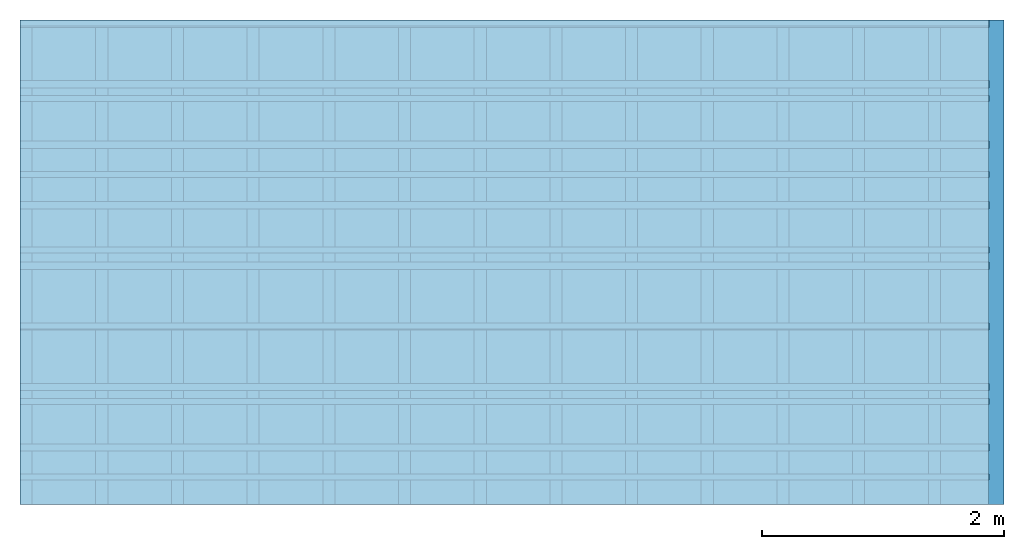
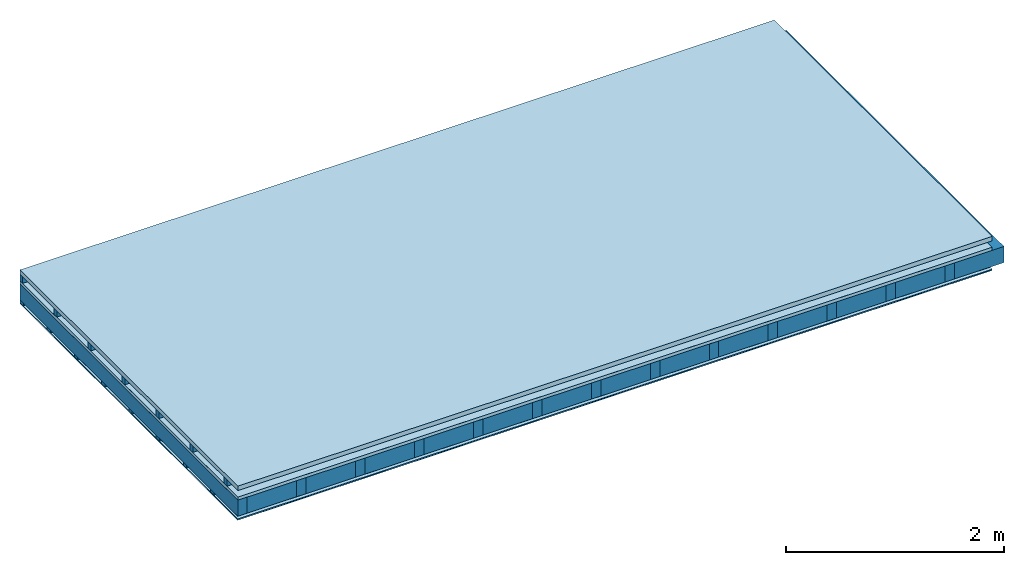
# One storey: 6 plates, 4 members, 1 element without a shape of its own.
"""IFC4 building model written with IfcOpenShell, lengths in metres."""

from ifc_helpers import new_model, si_unit, derived_unit, direction, frame, frame_2d, origin, origin_with_axes, place, context, project, spatial, rectangle, extrude, material, layer, layer_set, type_object, element, aggregate, save


model = new_model("IFC4")

# Units and contexts
plan_context = context("Plan", 3, precision=1e-05, world=origin(), true_north=direction((0.0, 1.0)))
model_context = context("Model", 3, precision=1e-05, world=origin(), true_north=direction((0.0, 1.0)))
ifc_project = project(units=[si_unit("LENGTHUNIT", "METRE"), derived_unit("SOUNDPRESSUREUNIT", [(si_unit("PRESSUREUNIT", "PASCAL", prefix="MICRO"), 0)]), si_unit("ENERGYUNIT", "JOULE", prefix="MEGA"), si_unit("MASSUNIT", "GRAM", prefix="KILO"), derived_unit("THERMALTRANSMITTANCEUNIT", [(si_unit("POWERUNIT", "WATT"), 1), (si_unit("AREAUNIT", "SQUARE_METRE"), -1), (si_unit("THERMODYNAMICTEMPERATUREUNIT", "KELVIN"), -1)]), derived_unit("AREADENSITYUNIT", [(si_unit("MASSUNIT", "GRAM", prefix="KILO"), 1), (si_unit("AREAUNIT", "SQUARE_METRE"), -1)]), derived_unit("USERDEFINED", [(si_unit("ENERGYUNIT", "JOULE", prefix="MEGA"), 1), (si_unit("AREAUNIT", "SQUARE_METRE"), -1)])], contexts=[plan_context, model_context])

# Site, building, storey
site = spatial("IfcSite", under=ifc_project)
building_placement = place(None, origin())
building = spatial("IfcBuilding", under=site, at=building_placement)
storey_placement = place(building_placement, origin())
storey = spatial("IfcBuildingStorey", under=building, at=storey_placement)

# Slab, members, plates
ifc_material_1 = material(Name="Roof tiles", Category="03.015")
ifc_layer_1 = layer(ifc_material_1, 0.05, Name="Roofing")
ifc_layer_2 = layer(None, 0.072, Name="Battens / profiles")
ifc_material_2 = material(Name="Roofing underlay", Category="09.008")
ifc_layer_3 = layer(ifc_material_2, 0.00018, Name="Under the roof")
ifc_material_3 = material(Category="10.009")
ifc_layer_4 = layer(ifc_material_3, 0.035, Name="Sub-floor")
ifc_material_4 = material(Name="of the art")
ifc_layer_5 = layer(ifc_material_4, 0.0, Name="Bond")
ifc_layer_6 = layer(None, 0.18, Name="Supporting structure")
ifc_material_5 = material(Name="Vapor barrier polyethylene (PE)", Category="09.002")
ifc_layer_7 = layer(ifc_material_5, 0.00025, Name="Vapor barrier")
ifc_layer_8 = layer(None, 0.03, Name="Battens / profiles")
ifc_material_6 = material(Name="Plasterboard type A", Category="03.008")
ifc_layer_9 = layer(ifc_material_6, 0.0125, Name="Covering below 1st layer")
ifc_material_7 = material(Category="04.001")
ifc_layer_10 = layer(ifc_material_7, 0.003, Name="Surface below")
ifc_layer_set = layer_set([ifc_layer_1, ifc_layer_2, ifc_layer_3, ifc_layer_4, ifc_layer_5, ifc_layer_6, ifc_layer_7, ifc_layer_8, ifc_layer_9, ifc_layer_10])
slab_type = type_object("IfcSlabType", Name="E0187", PredefinedType="NOTDEFINED", material=ifc_layer_set)
slab_placement = place(None, frame((0.0, 0.0, 0.0), z_axis=(0.0, 0.0, -1.0), x_axis=(1.0, 0.0, 0.0)))
slab = element("IfcSlab", 1, at=slab_placement, inside=storey, type_object=slab_type, material=ifc_layer_set, Name="Slab #1")
ifc_material_8 = material()
member_1_placement = place(slab_placement, origin())
member_1 = element("IfcMember", 2, at=member_1_placement, material=ifc_material_8, Name="Battens / profiles", context=plan_context, shape_type="SweptSolid", body=[
    extrude(rectangle(XDim=0.05, YDim=0.072, at=frame_2d((0.025, 0.036), x_axis=(1.0, 0.0))), frame((0.0, 0.0, 0.05), z_axis=(1.0, 0.0, 0.0), x_axis=(0.0, 1.0, 0.0)), (0.0, 0.0, 1.0), 8.0),
    extrude(rectangle(XDim=0.05, YDim=0.072, at=frame_2d((0.025, 0.036), x_axis=(1.0, 0.0))), frame((0.0, 0.625, 0.05), z_axis=(1.0, 0.0, 0.0), x_axis=(0.0, 1.0, 0.0)), (0.0, 0.0, 1.0), 8.0),
    extrude(rectangle(XDim=0.05, YDim=0.072, at=frame_2d((0.025, 0.036), x_axis=(1.0, 0.0))), frame((0.0, 1.25, 0.05), z_axis=(1.0, 0.0, 0.0), x_axis=(0.0, 1.0, 0.0)), (0.0, 0.0, 1.0), 8.0),
    extrude(rectangle(XDim=0.05, YDim=0.072, at=frame_2d((0.025, 0.036), x_axis=(1.0, 0.0))), frame((0.0, 1.875, 0.05), z_axis=(1.0, 0.0, 0.0), x_axis=(0.0, 1.0, 0.0)), (0.0, 0.0, 1.0), 8.0),
    extrude(rectangle(XDim=0.05, YDim=0.072, at=frame_2d((0.025, 0.036), x_axis=(1.0, 0.0))), frame((0.0, 2.5, 0.05), z_axis=(1.0, 0.0, 0.0), x_axis=(0.0, 1.0, 0.0)), (0.0, 0.0, 1.0), 8.0),
    extrude(rectangle(XDim=0.05, YDim=0.072, at=frame_2d((0.025, 0.036), x_axis=(1.0, 0.0))), frame((0.0, 3.125, 0.05), z_axis=(1.0, 0.0, 0.0), x_axis=(0.0, 1.0, 0.0)), (0.0, 0.0, 1.0), 8.0),
    extrude(rectangle(XDim=0.05, YDim=0.072, at=frame_2d((0.025, 0.036), x_axis=(1.0, 0.0))), frame((0.0, 3.75, 0.05), z_axis=(1.0, 0.0, 0.0), x_axis=(0.0, 1.0, 0.0)), (0.0, 0.0, 1.0), 8.0),
])
ifc_material_9 = material()
member_2_placement = place(slab_placement, origin())
member_2 = element("IfcMember", 3, at=member_2_placement, material=ifc_material_9, Name="Supporting structure", context=plan_context, shape_type="SweptSolid", body=[
    extrude(rectangle(XDim=0.1, YDim=0.18, at=frame_2d((0.05, 0.09), x_axis=(1.0, 0.0))), frame((0.0, 4.0, 0.15718), z_axis=(0.0, -1.0, 0.0), x_axis=(1.0, 0.0, 0.0)), (0.0, 0.0, 1.0), 4.0),
    extrude(rectangle(XDim=0.1, YDim=0.18, at=frame_2d((0.05, 0.09), x_axis=(1.0, 0.0))), frame((0.625, 4.0, 0.15718), z_axis=(0.0, -1.0, 0.0), x_axis=(1.0, 0.0, 0.0)), (0.0, 0.0, 1.0), 4.0),
    extrude(rectangle(XDim=0.1, YDim=0.18, at=frame_2d((0.05, 0.09), x_axis=(1.0, 0.0))), frame((1.25, 4.0, 0.15718), z_axis=(0.0, -1.0, 0.0), x_axis=(1.0, 0.0, 0.0)), (0.0, 0.0, 1.0), 4.0),
    extrude(rectangle(XDim=0.1, YDim=0.18, at=frame_2d((0.05, 0.09), x_axis=(1.0, 0.0))), frame((1.875, 4.0, 0.15718), z_axis=(0.0, -1.0, 0.0), x_axis=(1.0, 0.0, 0.0)), (0.0, 0.0, 1.0), 4.0),
    extrude(rectangle(XDim=0.1, YDim=0.18, at=frame_2d((0.05, 0.09), x_axis=(1.0, 0.0))), frame((2.5, 4.0, 0.15718), z_axis=(0.0, -1.0, 0.0), x_axis=(1.0, 0.0, 0.0)), (0.0, 0.0, 1.0), 4.0),
    extrude(rectangle(XDim=0.1, YDim=0.18, at=frame_2d((0.05, 0.09), x_axis=(1.0, 0.0))), frame((3.125, 4.0, 0.15718), z_axis=(0.0, -1.0, 0.0), x_axis=(1.0, 0.0, 0.0)), (0.0, 0.0, 1.0), 4.0),
    extrude(rectangle(XDim=0.1, YDim=0.18, at=frame_2d((0.05, 0.09), x_axis=(1.0, 0.0))), frame((3.75, 4.0, 0.15718), z_axis=(0.0, -1.0, 0.0), x_axis=(1.0, 0.0, 0.0)), (0.0, 0.0, 1.0), 4.0),
    extrude(rectangle(XDim=0.1, YDim=0.18, at=frame_2d((0.05, 0.09), x_axis=(1.0, 0.0))), frame((4.375, 4.0, 0.15718), z_axis=(0.0, -1.0, 0.0), x_axis=(1.0, 0.0, 0.0)), (0.0, 0.0, 1.0), 4.0),
    extrude(rectangle(XDim=0.1, YDim=0.18, at=frame_2d((0.05, 0.09), x_axis=(1.0, 0.0))), frame((5.0, 4.0, 0.15718), z_axis=(0.0, -1.0, 0.0), x_axis=(1.0, 0.0, 0.0)), (0.0, 0.0, 1.0), 4.0),
    extrude(rectangle(XDim=0.1, YDim=0.18, at=frame_2d((0.05, 0.09), x_axis=(1.0, 0.0))), frame((5.625, 4.0, 0.15718), z_axis=(0.0, -1.0, 0.0), x_axis=(1.0, 0.0, 0.0)), (0.0, 0.0, 1.0), 4.0),
    extrude(rectangle(XDim=0.1, YDim=0.18, at=frame_2d((0.05, 0.09), x_axis=(1.0, 0.0))), frame((6.25, 4.0, 0.15718), z_axis=(0.0, -1.0, 0.0), x_axis=(1.0, 0.0, 0.0)), (0.0, 0.0, 1.0), 4.0),
    extrude(rectangle(XDim=0.1, YDim=0.18, at=frame_2d((0.05, 0.09), x_axis=(1.0, 0.0))), frame((6.875, 4.0, 0.15718), z_axis=(0.0, -1.0, 0.0), x_axis=(1.0, 0.0, 0.0)), (0.0, 0.0, 1.0), 4.0),
    extrude(rectangle(XDim=0.1, YDim=0.18, at=frame_2d((0.05, 0.09), x_axis=(1.0, 0.0))), frame((7.5, 4.0, 0.15718), z_axis=(0.0, -1.0, 0.0), x_axis=(1.0, 0.0, 0.0)), (0.0, 0.0, 1.0), 4.0),
])
ifc_material_10 = material(Name="Mineral wool")
member_3_placement = place(slab_placement, origin())
member_3 = element("IfcMember", 4, at=member_3_placement, material=ifc_material_10, Name="Cavity", context=plan_context, shape_type="SweptSolid", body=[
    extrude(rectangle(XDim=0.525, YDim=0.18, at=frame_2d((0.2625, 0.09), x_axis=(1.0, 0.0))), frame((0.1, 4.0, 0.15718), z_axis=(0.0, -1.0, 0.0), x_axis=(1.0, 0.0, 0.0)), (0.0, 0.0, 1.0), 4.0),
    extrude(rectangle(XDim=0.525, YDim=0.18, at=frame_2d((0.2625, 0.09), x_axis=(1.0, 0.0))), frame((0.725, 4.0, 0.15718), z_axis=(0.0, -1.0, 0.0), x_axis=(1.0, 0.0, 0.0)), (0.0, 0.0, 1.0), 4.0),
    extrude(rectangle(XDim=0.525, YDim=0.18, at=frame_2d((0.2625, 0.09), x_axis=(1.0, 0.0))), frame((1.35, 4.0, 0.15718), z_axis=(0.0, -1.0, 0.0), x_axis=(1.0, 0.0, 0.0)), (0.0, 0.0, 1.0), 4.0),
    extrude(rectangle(XDim=0.525, YDim=0.18, at=frame_2d((0.2625, 0.09), x_axis=(1.0, 0.0))), frame((1.975, 4.0, 0.15718), z_axis=(0.0, -1.0, 0.0), x_axis=(1.0, 0.0, 0.0)), (0.0, 0.0, 1.0), 4.0),
    extrude(rectangle(XDim=0.525, YDim=0.18, at=frame_2d((0.2625, 0.09), x_axis=(1.0, 0.0))), frame((2.6, 4.0, 0.15718), z_axis=(0.0, -1.0, 0.0), x_axis=(1.0, 0.0, 0.0)), (0.0, 0.0, 1.0), 4.0),
    extrude(rectangle(XDim=0.525, YDim=0.18, at=frame_2d((0.2625, 0.09), x_axis=(1.0, 0.0))), frame((3.225, 4.0, 0.15718), z_axis=(0.0, -1.0, 0.0), x_axis=(1.0, 0.0, 0.0)), (0.0, 0.0, 1.0), 4.0),
    extrude(rectangle(XDim=0.525, YDim=0.18, at=frame_2d((0.2625, 0.09), x_axis=(1.0, 0.0))), frame((3.85, 4.0, 0.15718), z_axis=(0.0, -1.0, 0.0), x_axis=(1.0, 0.0, 0.0)), (0.0, 0.0, 1.0), 4.0),
    extrude(rectangle(XDim=0.525, YDim=0.18, at=frame_2d((0.2625, 0.09), x_axis=(1.0, 0.0))), frame((4.475, 4.0, 0.15718), z_axis=(0.0, -1.0, 0.0), x_axis=(1.0, 0.0, 0.0)), (0.0, 0.0, 1.0), 4.0),
    extrude(rectangle(XDim=0.525, YDim=0.18, at=frame_2d((0.2625, 0.09), x_axis=(1.0, 0.0))), frame((5.1, 4.0, 0.15718), z_axis=(0.0, -1.0, 0.0), x_axis=(1.0, 0.0, 0.0)), (0.0, 0.0, 1.0), 4.0),
    extrude(rectangle(XDim=0.525, YDim=0.18, at=frame_2d((0.2625, 0.09), x_axis=(1.0, 0.0))), frame((5.725, 4.0, 0.15718), z_axis=(0.0, -1.0, 0.0), x_axis=(1.0, 0.0, 0.0)), (0.0, 0.0, 1.0), 4.0),
    extrude(rectangle(XDim=0.525, YDim=0.18, at=frame_2d((0.2625, 0.09), x_axis=(1.0, 0.0))), frame((6.35, 4.0, 0.15718), z_axis=(0.0, -1.0, 0.0), x_axis=(1.0, 0.0, 0.0)), (0.0, 0.0, 1.0), 4.0),
    extrude(rectangle(XDim=0.525, YDim=0.18, at=frame_2d((0.2625, 0.09), x_axis=(1.0, 0.0))), frame((6.975, 4.0, 0.15718), z_axis=(0.0, -1.0, 0.0), x_axis=(1.0, 0.0, 0.0)), (0.0, 0.0, 1.0), 4.0),
    extrude(rectangle(XDim=0.525, YDim=0.18, at=frame_2d((0.2625, 0.09), x_axis=(1.0, 0.0))), frame((7.6, 4.0, 0.15718), z_axis=(0.0, -1.0, 0.0), x_axis=(1.0, 0.0, 0.0)), (0.0, 0.0, 1.0), 4.0),
])
ifc_material_11 = material()
member_4_placement = place(slab_placement, origin())
member_4 = element("IfcMember", 5, at=member_4_placement, material=ifc_material_11, Name="Battens / profiles", context=plan_context, shape_type="SweptSolid", body=[
    extrude(rectangle(XDim=0.06, YDim=0.03, at=frame_2d((0.03, 0.015), x_axis=(1.0, 0.0))), frame((0.0, 0.0, 0.33743), z_axis=(1.0, 0.0, 0.0), x_axis=(0.0, 1.0, 0.0)), (0.0, 0.0, 1.0), 8.0),
    extrude(rectangle(XDim=0.06, YDim=0.03, at=frame_2d((0.03, 0.015), x_axis=(1.0, 0.0))), frame((0.0, 0.5, 0.33743), z_axis=(1.0, 0.0, 0.0), x_axis=(0.0, 1.0, 0.0)), (0.0, 0.0, 1.0), 8.0),
    extrude(rectangle(XDim=0.06, YDim=0.03, at=frame_2d((0.03, 0.015), x_axis=(1.0, 0.0))), frame((0.0, 1.0, 0.33743), z_axis=(1.0, 0.0, 0.0), x_axis=(0.0, 1.0, 0.0)), (0.0, 0.0, 1.0), 8.0),
    extrude(rectangle(XDim=0.06, YDim=0.03, at=frame_2d((0.03, 0.015), x_axis=(1.0, 0.0))), frame((0.0, 1.5, 0.33743), z_axis=(1.0, 0.0, 0.0), x_axis=(0.0, 1.0, 0.0)), (0.0, 0.0, 1.0), 8.0),
    extrude(rectangle(XDim=0.06, YDim=0.03, at=frame_2d((0.03, 0.015), x_axis=(1.0, 0.0))), frame((0.0, 2.0, 0.33743), z_axis=(1.0, 0.0, 0.0), x_axis=(0.0, 1.0, 0.0)), (0.0, 0.0, 1.0), 8.0),
    extrude(rectangle(XDim=0.06, YDim=0.03, at=frame_2d((0.03, 0.015), x_axis=(1.0, 0.0))), frame((0.0, 2.5, 0.33743), z_axis=(1.0, 0.0, 0.0), x_axis=(0.0, 1.0, 0.0)), (0.0, 0.0, 1.0), 8.0),
    extrude(rectangle(XDim=0.06, YDim=0.03, at=frame_2d((0.03, 0.015), x_axis=(1.0, 0.0))), frame((0.0, 3.0, 0.33743), z_axis=(1.0, 0.0, 0.0), x_axis=(0.0, 1.0, 0.0)), (0.0, 0.0, 1.0), 8.0),
    extrude(rectangle(XDim=0.06, YDim=0.03, at=frame_2d((0.03, 0.015), x_axis=(1.0, 0.0))), frame((0.0, 3.5, 0.33743), z_axis=(1.0, 0.0, 0.0), x_axis=(0.0, 1.0, 0.0)), (0.0, 0.0, 1.0), 8.0),
])
plate_1_placement = place(slab_placement, origin())
plate_1 = element("IfcPlate", 6, at=plate_1_placement, material=ifc_material_1, Name="Roofing", context=plan_context, shape_type="SweptSolid", body=[
    extrude(rectangle(XDim=8.0, YDim=4.0, at=frame_2d((4.0, 2.0), x_axis=(1.0, 0.0))), origin_with_axes(), (0.0, 0.0, 1.0), 0.05),
])
plate_2_placement = place(slab_placement, origin())
plate_2 = element("IfcPlate", 7, at=plate_2_placement, material=ifc_material_2, Name="Under the roof", context=plan_context, shape_type="SweptSolid", body=[
    extrude(rectangle(XDim=8.0, YDim=4.0, at=frame_2d((4.0, 2.0), x_axis=(1.0, 0.0))), frame((0.0, 0.0, 0.122), z_axis=(0.0, 0.0, 1.0), x_axis=(1.0, 0.0, 0.0)), (0.0, 0.0, 1.0), 0.00018),
])
plate_3_placement = place(slab_placement, origin())
plate_3 = element("IfcPlate", 8, at=plate_3_placement, material=ifc_material_3, Name="Sub-floor", context=plan_context, shape_type="SweptSolid", body=[
    extrude(rectangle(XDim=8.0, YDim=4.0, at=frame_2d((4.0, 2.0), x_axis=(1.0, 0.0))), frame((0.0, 0.0, 0.12218), z_axis=(0.0, 0.0, 1.0), x_axis=(1.0, 0.0, 0.0)), (0.0, 0.0, 1.0), 0.035),
])
plate_4_placement = place(slab_placement, origin())
plate_4 = element("IfcPlate", 9, at=plate_4_placement, material=ifc_material_5, Name="Vapor barrier", context=plan_context, shape_type="SweptSolid", body=[
    extrude(rectangle(XDim=8.0, YDim=4.0, at=frame_2d((4.0, 2.0), x_axis=(1.0, 0.0))), frame((0.0, 0.0, 0.33718), z_axis=(0.0, 0.0, 1.0), x_axis=(1.0, 0.0, 0.0)), (0.0, 0.0, 1.0), 0.00025),
])
plate_5_placement = place(slab_placement, origin())
plate_5 = element("IfcPlate", 10, at=plate_5_placement, material=ifc_material_6, Name="Covering below 1st layer", context=plan_context, shape_type="SweptSolid", body=[
    extrude(rectangle(XDim=8.0, YDim=4.0, at=frame_2d((4.0, 2.0), x_axis=(1.0, 0.0))), frame((0.0, 0.0, 0.36743), z_axis=(0.0, 0.0, 1.0), x_axis=(1.0, 0.0, 0.0)), (0.0, 0.0, 1.0), 0.0125),
])
plate_6_placement = place(slab_placement, origin())
plate_6 = element("IfcPlate", 11, at=plate_6_placement, material=ifc_material_7, Name="Surface below", context=plan_context, shape_type="SweptSolid", body=[
    extrude(rectangle(XDim=8.0, YDim=4.0, at=frame_2d((4.0, 2.0), x_axis=(1.0, 0.0))), frame((0.0, 0.0, 0.37993), z_axis=(0.0, 0.0, 1.0), x_axis=(1.0, 0.0, 0.0)), (0.0, 0.0, 1.0), 0.003),
])
aggregate(slab, [plate_1, member_1, plate_2, plate_3, member_2, member_3, plate_4, member_4, plate_5, plate_6])

save(model, "model.ifc")
